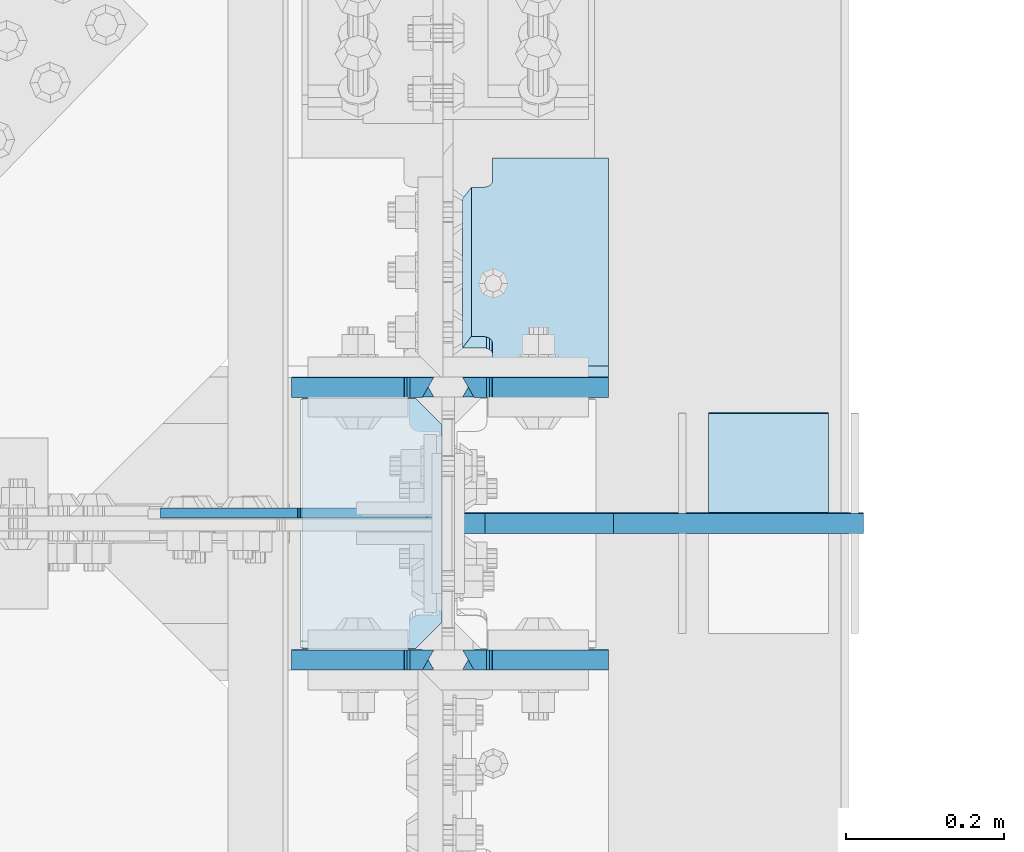
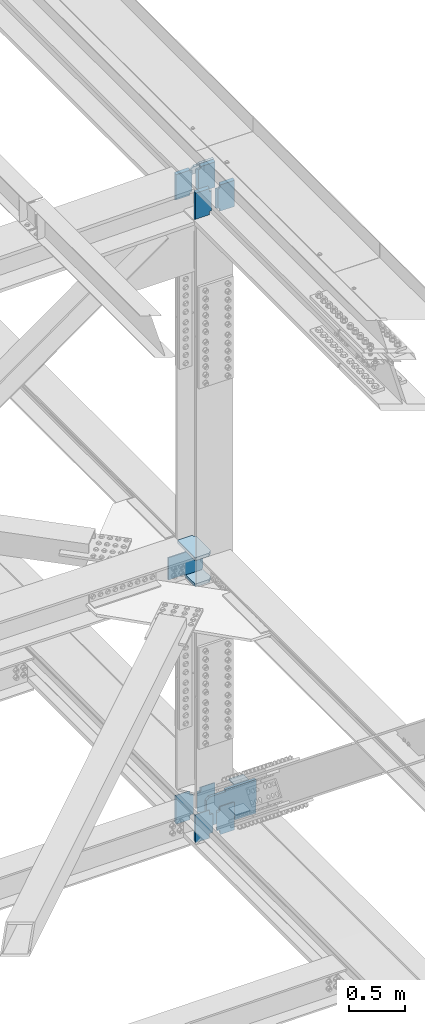
# One storey, part 3601 of 3843: 15 plates, 5 elements without a shape of their own.
"""IFC2X3 building model written with IfcOpenShell, lengths in millimetres."""

from ifc_helpers import new_model, si_unit, frame, origin_with_axes, place, context, subcontext, project, spatial, faceted_brep, material, type_object, element, aggregate, save


model = new_model("IFC2X3")

# Units and contexts
model_context = context("Model", 3, precision=1e-05, world=origin_with_axes())
body_context = subcontext(model_context, "Body", "Model", "MODEL_VIEW")
ifc_project = project(units=[si_unit("LENGTHUNIT", "METRE", prefix="MILLI"), si_unit("AREAUNIT", "SQUARE_METRE"), si_unit("VOLUMEUNIT", "CUBIC_METRE"), si_unit("MASSUNIT", "GRAM", prefix="KILO"), si_unit("TIMEUNIT", "SECOND"), si_unit("PLANEANGLEUNIT", "RADIAN"), si_unit("SOLIDANGLEUNIT", "STERADIAN"), si_unit("THERMODYNAMICTEMPERATUREUNIT", "DEGREE_CELSIUS"), si_unit("LUMINOUSINTENSITYUNIT", "LUMEN")], contexts=[model_context])

# Site, building, storey
site_placement = place(None, origin_with_axes())
site = spatial("IfcSite", under=ifc_project, at=site_placement, CompositionType="ELEMENT")
building_placement = place(site_placement, origin_with_axes())
building = spatial("IfcBuilding", under=site, at=building_placement, Name="Undefined", CompositionType="ELEMENT")
storey_placement = place(building_placement, origin_with_axes())
storey = spatial("IfcBuildingStorey", under=building, at=storey_placement, Name="Undefined", CompositionType="ELEMENT", Elevation=0.0)

# Assembly, plates
assembly_1_placement = place(storey_placement, origin_with_axes())
assembly_1 = element("IfcElementAssembly", 1, at=assembly_1_placement, inside=storey, Name="BEAM", AssemblyPlace="NOTDEFINED", PredefinedType="RIGID_FRAME")
ifc_material = material(Name="STEEL/A572-50")
plate_type_1 = type_object("IfcPlateType", PredefinedType="NOTDEFINED")
plate_1_placement = place(assembly_1_placement, frame((85852.0, 50385.630793258, 46161.5692750929), z_axis=(0.0, -0.000625967000050877, 0.999999804082638), x_axis=(-1.0, 0.0, 0.0)))
plate_1 = element("IfcPlate", 2, at=plate_1_placement, type_object=plate_type_1, material=ifc_material, Name="PLATE", context=body_context, shape_type="Brep", body=[
    faceted_brep([(146.843749999985, -12.7000000008702, 314.304894549285), (146.843749999985, 12.6999999991167, 299.813402791253), (0.0, 12.6999999991167, 299.813402791253), (0.0, -12.7000000008702, 314.304894549285), (146.843749999985, 12.7000000000553, 14.4914917584392), (146.843749999985, -12.7000000000844, 2.18278728425503e-11), (0.0, -12.6999999999971, 0.0), (0.0, 12.7000000000698, 14.4914917390415), (146.843749999985, 12.6999999999098, 38.1890602041385), (146.843749999985, -12.7000000001572, 38.1003132816259), (147.810479922569, 12.6999999998952, 43.0491693876829), (147.810479922569, -12.7000000001644, 42.9604224651703), (150.563493823051, 12.6999999998734, 47.169371005024), (150.563493823051, -12.7000000001863, 47.0806240825113), (154.683670291211, 12.6999999998734, 49.9224017096567), (154.683670291211, -12.7000000001935, 49.833654787144), (159.543749809251, 12.6999999998661, 50.8891375330786), (159.543749809251, -12.7000000001935, 50.800390610566), (170.452258242993, 12.700000000099, 50.8891375249077), (184.943749999991, -12.7000000000116, 50.8003906183731), (184.943749999991, -12.6999999997643, 263.417469235843), (170.452258242993, 12.7000000003609, 263.506216142385), (159.543749809251, 12.6999999992186, 263.506216155103), (159.543749809251, -12.7000000008484, 263.417469232591), (154.683670291211, 12.6999999992113, 264.472951978518), (154.683670291211, -12.7000000008557, 264.384205056005), (150.563493823051, 12.699999999204, 267.225982683158), (150.563493823051, -12.7000000008629, 267.137235760645), (147.810479922569, 12.6999999991895, 271.346184300499), (147.810479922569, -12.7000000008702, 271.257437377986), (146.843749999985, 12.6999999991749, 276.206293484036), (146.843749999985, -12.7000000008848, 276.117546561523)], [[[0, 1, 2, 3]], [[4, 5, 6, 7]], [[8, 9, 5, 4]], [[9, 8, 10, 11]], [[11, 10, 12, 13]], [[13, 12, 14, 15]], [[15, 14, 16, 17]], [[17, 16, 18, 19]], [[20, 19, 18, 21]], [[22, 23, 20, 21]], [[23, 22, 24, 25]], [[25, 24, 26, 27]], [[27, 26, 28, 29]], [[29, 28, 30, 31]], [[6, 5, 9, 11, 13, 15, 17, 19, 20, 23, 25, 27, 29, 31, 0, 3]], [[7, 6, 3, 2]], [[30, 28, 26, 24, 22, 21, 18, 16, 14, 12, 10, 8, 4, 7, 2, 1]], [[31, 30, 1, 0]]]),
])
plate_2_placement = place(assembly_1_placement, frame((85852.0, 50731.7055400802, 46162.082048219), z_axis=(0.0, -0.000625967000050877, 0.999999804082638), x_axis=(-1.0, 0.0, 0.0)))
plate_2 = element("IfcPlate", 3, at=plate_2_placement, type_object=plate_type_1, material=ifc_material, Name="PLATE", context=body_context, shape_type="Brep", body=[
    faceted_brep([(146.843749999985, -12.7000000001572, 38.1003132816259), (146.843749999985, 12.6999999999098, 38.1890602041385), (147.810479922569, 12.6999999998952, 43.0491693876829), (147.810479922569, -12.7000000001644, 42.9604224651703), (150.563493823051, 12.6999999998734, 47.169371005024), (150.563493823051, -12.7000000001863, 47.0806240825113), (154.683670291211, 12.6999999998734, 49.9224017096567), (154.683670291211, -12.7000000001935, 49.833654787144), (159.543749809251, 12.6999999998661, 50.8891375330786), (159.543749809251, -12.7000000001935, 50.800390610566), (170.452258242993, 12.700000000099, 50.8891375249077), (184.943749999991, -12.7000000000116, 50.8003906183731), (184.943749999991, -12.6999999997643, 263.417469235843), (170.452258242993, 12.7000000003609, 263.506216142385), (159.543749809251, 12.6999999992186, 263.506216155103), (159.543749809251, -12.7000000008484, 263.417469232591), (154.683670291211, 12.6999999992113, 264.472951978518), (154.683670291211, -12.7000000008557, 264.384205056005), (150.563493823051, 12.699999999204, 267.225982683158), (150.563493823051, -12.7000000008629, 267.137235760645), (147.810479922569, 12.6999999991895, 271.346184300499), (147.810479922569, -12.7000000008702, 271.257437377986), (146.843749999985, 12.6999999991749, 276.206293484036), (146.843749999985, -12.7000000008848, 276.117546561523), (146.843749999985, -12.7000000008484, 304.256557997855), (146.843749999985, 12.6999999991313, 289.76506625802), (0.0, 12.6999999991313, 289.76506625802), (0.0, -12.7000000008484, 304.256557997855), (0.0, -12.6999999999971, 0.0), (146.843749999985, -12.7000000000844, 2.18278728425503e-11), (146.843749999985, 12.7000000000553, 14.4914917584392), (0.0, 12.7000000000698, 14.4914917390415)], [[[0, 1, 2, 3]], [[3, 2, 4, 5]], [[5, 4, 6, 7]], [[7, 6, 8, 9]], [[9, 8, 10, 11]], [[12, 11, 10, 13]], [[14, 15, 12, 13]], [[15, 14, 16, 17]], [[17, 16, 18, 19]], [[19, 18, 20, 21]], [[21, 20, 22, 23]], [[24, 23, 22, 25]], [[26, 27, 24, 25]], [[0, 3, 5, 7, 9, 11, 12, 15, 17, 19, 21, 23, 24, 27, 28, 29]], [[1, 0, 29, 30]], [[26, 25, 22, 20, 18, 16, 14, 13, 10, 8, 6, 4, 2, 1, 30, 31]], [[27, 26, 31, 28]], [[30, 29, 28, 31]]]),
])

assembly_2_placement = place(storey_placement, origin_with_axes())
assembly_2 = element("IfcElementAssembly", 4, at=assembly_2_placement, inside=storey, Name="BEAM", AssemblyPlace="NOTDEFINED", PredefinedType="RIGID_FRAME")
plate_3_placement = place(assembly_2_placement, frame((85852.0, 50385.9360791615, 39389.280812488), z_axis=(0.0, -0.000749054000341859, 0.999999719459013), x_axis=(-1.0, 0.0, 0.0)))
plate_3 = element("IfcPlate", 5, at=plate_3_placement, type_object=plate_type_1, material=ifc_material, Name="PLATE", context=body_context, shape_type="Brep", body=[
    faceted_brep([(146.843749999985, 12.7000000002517, 314.307894929545), (0.0, 12.7000000002517, 314.307894929545), (0.0, -12.6999999998152, 299.816403173951), (146.843749999985, -12.6999999998152, 299.816403173951), (0.0, -12.7000000000044, 24.1021473603178), (0.0, 12.7000000000335, 9.46280752972962), (146.843749999985, 12.7000000000335, 9.46280752972962), (146.843749999985, -12.7000000000044, 24.1021473603178), (146.843749999985, 12.7000000000553, 47.5562269457077), (146.843749999985, -12.6999999999898, 47.4674800128851), (147.810479922569, 12.7000000000626, 52.4163361292522), (147.810479922569, -12.6999999999898, 52.3275891964222), (150.563493823051, 12.7000000000626, 56.5365377465932), (150.563493823051, -12.6999999999825, 56.4477908137706), (154.683670291211, 12.7000000000626, 59.2895684512259), (154.683670291211, -12.6999999999825, 59.200821518396), (159.543749809251, 12.7000000000626, 60.2563042746406), (159.543749809251, -12.6999999999825, 60.1675573418179), (184.943749999991, 12.7000000000626, 60.2563042746406), (170.452258243167, -12.6999999999825, 60.1675573418179), (184.943749999991, 12.7000000002081, 263.506216153903), (170.452258242891, -12.699999999837, 263.417469255888), (159.543749809251, 12.6999999992186, 263.506216155103), (159.543749809251, -12.7000000008484, 263.417469232591), (154.683670291211, 12.6999999992113, 264.472951978518), (154.683670291211, -12.7000000008557, 264.384205056005), (150.563493823051, 12.699999999204, 267.225982683158), (150.563493823051, -12.7000000008629, 267.137235760645), (147.810479922569, 12.6999999991895, 271.346184300499), (147.810479922569, -12.7000000008702, 271.257437377986), (146.843749999985, 12.6999999991749, 276.206293484036), (146.843749999985, -12.7000000008848, 276.117546561523)], [[[0, 1, 2, 3]], [[4, 5, 6, 7]], [[7, 6, 8, 9]], [[9, 8, 10, 11]], [[11, 10, 12, 13]], [[13, 12, 14, 15]], [[15, 14, 16, 17]], [[17, 16, 18, 19]], [[20, 21, 19, 18]], [[22, 23, 21, 20]], [[23, 22, 24, 25]], [[25, 24, 26, 27]], [[27, 26, 28, 29]], [[29, 28, 30, 31]], [[31, 30, 0, 3]], [[4, 7, 9, 11, 13, 15, 17, 19, 21, 23, 25, 27, 29, 31, 3, 2]], [[5, 4, 2, 1]], [[30, 28, 26, 24, 22, 20, 18, 16, 14, 12, 10, 8, 6, 5, 1, 0]]]),
])
plate_4_placement = place(assembly_2_placement, frame((85852.0, 50732.0108082423, 39389.7721094519), z_axis=(0.0, -0.000749054000341859, 0.999999719459013), x_axis=(-1.0, 0.0, 0.0)))
plate_4 = element("IfcPlate", 6, at=plate_4_placement, type_object=plate_type_1, material=ifc_material, Name="PLATE", context=body_context, shape_type="Brep", body=[
    faceted_brep([(146.843749999985, 12.7000000002372, 314.309363755092), (0.0, 12.7000000002372, 314.309363755092), (0.0, -12.6999999998152, 299.817871999512), (146.843749999985, -12.6999999998152, 299.817871999512), (146.843749999985, -12.7000000000771, 14.4914917543283), (0.0, -12.7000000000771, 14.4914917543283), (0.0, 12.6999999999971, 0.0), (146.843749999985, 12.7000000000262, 4.36557456851006e-11), (146.843749999985, 12.6999999999098, 38.1890602041385), (146.843749999985, -12.7000000001572, 38.1003132816259), (147.810479922569, 12.6999999998952, 43.0491693876829), (147.810479922569, -12.7000000001644, 42.9604224651703), (150.563493823051, 12.6999999998734, 47.169371005024), (150.563493823051, -12.7000000001863, 47.0806240825113), (154.683670291211, 12.6999999998734, 49.9224017096567), (154.683670291211, -12.7000000001935, 49.833654787144), (159.543749809251, 12.6999999998661, 50.8891375330786), (159.543749809251, -12.7000000001935, 50.800390610566), (184.943749999991, 12.7000000001572, 50.8891375333405), (170.452258242833, -12.7000000000262, 50.800390609882), (184.943749999991, 12.7000000002081, 263.506216153903), (170.452258242891, -12.699999999837, 263.417469255888), (159.543749809251, 12.6999999992186, 263.506216155103), (159.543749809251, -12.7000000008484, 263.417469232591), (154.683670291211, 12.6999999992113, 264.472951978518), (154.683670291211, -12.7000000008557, 264.384205056005), (150.563493823051, 12.699999999204, 267.225982683158), (150.563493823051, -12.7000000008629, 267.137235760645), (147.810479922569, 12.6999999991895, 271.346184300499), (147.810479922569, -12.7000000008702, 271.257437377986), (146.843749999985, 12.6999999991749, 276.206293484036), (146.843749999985, -12.7000000008848, 276.117546561523)], [[[0, 1, 2, 3]], [[4, 5, 6, 7]], [[8, 9, 4, 7]], [[9, 8, 10, 11]], [[11, 10, 12, 13]], [[13, 12, 14, 15]], [[15, 14, 16, 17]], [[17, 16, 18, 19]], [[20, 21, 19, 18]], [[22, 23, 21, 20]], [[23, 22, 24, 25]], [[25, 24, 26, 27]], [[27, 26, 28, 29]], [[29, 28, 30, 31]], [[31, 30, 0, 3]], [[5, 4, 9, 11, 13, 15, 17, 19, 21, 23, 25, 27, 29, 31, 3, 2]], [[6, 5, 2, 1]], [[30, 28, 26, 24, 22, 20, 18, 16, 14, 12, 10, 8, 7, 6, 1, 0]]]),
])

# Assembly, plate
assembly_3_placement = place(storey_placement, origin_with_axes())
assembly_3 = element("IfcElementAssembly", 7, at=assembly_3_placement, inside=storey, Name="COLUMN", AssemblyPlace="NOTDEFINED", PredefinedType="RIGID_FRAME")
plate_type_2 = type_object("IfcPlateType", PredefinedType="NOTDEFINED")
plate_5_placement = place(assembly_3_placement, frame((85640.8625, 50572.1937470839, 42209.615968616), z_axis=(-0.707106781186548, 0.0, 0.707106781186548), x_axis=(-0.707106781186548, 0.0, -0.707106781186548)))
plate_5 = element("IfcPlate", 8, at=plate_5_placement, type_object=plate_type_2, material=ifc_material, Name="PLATE", context=body_context, shape_type="Brep", body=[
    faceted_brep([(0.0, -6.3499999046162, 0.0), (-152.665721433397, -6.35000000000582, 152.665721433463), (-152.665721433397, 6.35000000000582, 152.665721433463), (7.27595761418343e-12, 6.3499999046162, 0.0), (-152.665721433092, -6.35000000000582, 179.606489796817), (-152.665721433092, 6.35000000000582, 179.606489796817), (-39.2899878478784, -6.35000000000582, 292.982223272138), (-39.2899878478784, 6.35000000000582, 292.982223272138), (-37.2516740051942, -6.35000000000582, 291.620265505095), (-37.2516740051942, 6.35000000000582, 291.620265505095), (-34.8473188920616, -6.35000000000582, 291.142009537525), (-34.8473188920616, 6.35000000000582, 291.142009537525), (-32.4429637789435, -6.35000000000582, 291.62026550512), (-32.4429637789435, 6.35000000000582, 291.62026550512), (-30.4046499362594, -6.35000000000582, 292.982223272178), (-30.4046499362594, 6.35000000000582, 292.982223272178), (90.8762668049167, -6.35000000000582, 414.263140013285), (90.8762668049167, 6.35000000000582, 414.263140013285), (261.50113310435, -6.35000000000582, 243.638273713757), (261.50113310435, 6.35000000000582, 243.638273713757), (140.316502018759, -6.35000000000582, 122.453642628203), (140.316502018759, 6.35000000000582, 122.453642628203), (138.925026635639, -6.35000000000582, 120.371152551248), (138.925026635639, 6.35000000000582, 120.371152551248), (138.43640545971, -6.35000000000582, 117.914688016841), (138.43640545971, 6.35000000000582, 117.914688016841), (138.92502663561, -6.35000000000582, 115.458223482437), (138.92502663561, 6.35000000000582, 115.458223482437), (140.316501893642, -6.34999999999854, 113.375733530571), (140.316501893642, 6.34999999999854, 113.375733530571), (26.9407683632217, -6.34999999999854, 1.30967237055302e-10), (26.9407683632217, 6.34999999999854, 1.30967237055302e-10)], [[[0, 1, 2, 3]], [[1, 4, 5, 2]], [[4, 6, 7, 5]], [[6, 8, 9, 7]], [[8, 10, 11, 9]], [[10, 12, 13, 11]], [[12, 14, 15, 13]], [[14, 16, 17, 15]], [[16, 18, 19, 17]], [[18, 20, 21, 19]], [[20, 22, 23, 21]], [[22, 24, 25, 23]], [[24, 26, 27, 25]], [[26, 28, 29, 27]], [[28, 30, 31, 29]], [[30, 0, 3, 31]], [[5, 7, 9, 11, 13, 15, 17, 19, 21, 23, 25, 27, 29, 31, 3, 2]], [[30, 28, 26, 24, 22, 20, 18, 16, 14, 12, 10, 8, 6, 4, 1, 0]]]),
])

# Plate
plate_type_3 = type_object("IfcPlateType", PredefinedType="NOTDEFINED")
plate_6_placement = place(assembly_1_placement, frame((85852.0, 51016.3130340256, 46167.7139471911), z_axis=(0.0, -0.655849171955138, 0.754891954948362), x_axis=(-1.0, 0.0, 0.0)))
plate_6 = element("IfcPlate", 9, at=plate_6_placement, type_object=plate_type_3, material=ifc_material, Name="PLATE", context=body_context, shape_type="Brep", body=[
    faceted_brep([(184.943749999991, 9.52499999934662, 346.724118745289), (173.831249999988, -9.52500000063446, 346.724118745449), (173.831249999988, -9.52500000008149, 58.1404139255465), (184.943749999991, 9.52499999988504, 58.1404139253573), (154.683670291211, -9.52500000008513, 57.1736840029625), (154.683670291211, 9.5249999998814, 57.1736840027879), (159.543749809251, 9.52499999988504, 58.1404139253573), (159.543749809251, -9.52500000008149, 58.1404139255465), (150.563493823051, -9.52500000007421, 54.4206701025396), (150.563493823051, 9.52499999989232, 54.420670102365), (147.810479922569, -9.52500000007058, 50.300493634466), (147.810479922569, 9.52499999991051, 50.3004936342913), (146.843749999985, -9.52500000005966, 45.4404141164996), (146.843749999985, 9.52499999991414, 45.440414116325), (146.843749999985, -9.52499999997599, 0.990413928826456), (146.843749999985, 9.52500000000146, 0.990413928739144), (0.0, -9.52499999997599, 0.990413928826456), (0.0, 9.52500000000146, 0.990413928739144), (0.0, -9.52500000073633, 403.87411874863), (0.0, 9.52499999923748, 403.874118748543), (146.843749999985, -9.52500000073633, 403.87411874863), (146.843749999985, 9.52499999923748, 403.874118748543), (146.843749999985, -9.52500000065993, 359.424118554482), (146.843749999985, 9.52499999932115, 359.424118554321), (147.810479922569, -9.52500000064174, 354.56403903653), (147.810479922569, 9.52499999932479, 354.564039036355), (150.563493823051, -9.5250000006381, 350.443862568442), (150.563493823051, 9.52499999934298, 350.443862568281), (154.683670291211, -9.5250000006381, 347.690848668033), (154.683670291211, 9.52499999933934, 347.690848667829), (159.543749809251, -9.52500000063446, 346.724118745449), (159.543749809251, 9.52499999934662, 346.724118745289)], [[[0, 1, 2, 3]], [[4, 5, 6, 7]], [[8, 9, 5, 4]], [[10, 11, 9, 8]], [[12, 13, 11, 10]], [[14, 15, 13, 12]], [[16, 17, 15, 14]], [[18, 19, 17, 16]], [[19, 18, 20, 21]], [[20, 22, 23, 21]], [[24, 25, 23, 22]], [[26, 27, 25, 24]], [[28, 29, 27, 26]], [[30, 31, 29, 28]], [[31, 30, 1, 0]], [[6, 5, 9, 11, 13, 15, 17, 19, 21, 23, 25, 27, 29, 31, 0, 3]], [[7, 6, 3, 2]], [[30, 28, 26, 24, 22, 20, 18, 16, 14, 12, 10, 8, 4, 7, 2, 1]]]),
])

plate_type_4 = type_object("IfcPlateType", PredefinedType="NOTDEFINED")
plate_7_placement = place(assembly_1_placement, frame((85630.54375, 50385.630793258, 46161.5692750929), z_axis=(0.0, -0.000625967000050877, 0.999999804082638), x_axis=(-1.0, 0.0, 0.0)))
plate_7 = element("IfcPlate", 10, at=plate_7_placement, type_object=plate_type_4, material=ifc_material, Name="PLATE", context=body_context, shape_type="Brep", body=[
    faceted_brep([(180.974999999991, 12.7000000000553, 14.4914917584392), (180.974999999991, -12.7000000000844, 2.18278728425503e-11), (38.1000000000058, -12.7000000000844, 2.18278728425503e-11), (38.1000000000058, 12.7000000000553, 14.4914917584392), (37.1332700774219, -12.7000000001644, 42.9604224651848), (37.1332700774219, 12.6999999998952, 43.0491693876975), (38.1000000000058, 12.6999999999098, 38.1890602041531), (38.1000000000058, -12.7000000001572, 38.1003132816404), (34.3802561769407, -12.7000000001863, 47.0806240825259), (34.3802561769407, 12.6999999998734, 47.1693710050386), (30.2600797087798, -12.7000000001935, 49.8336547871586), (30.2600797087798, 12.6999999998734, 49.9224017096712), (25.4000001907407, -12.7000000001935, 50.8003906105805), (25.4000001907407, 12.6999999998661, 50.8891375330932), (0.0, -12.7000000000262, 50.8003906045633), (14.4914917569986, 12.7000000001135, 50.8891375364256), (14.4914917569986, 12.7000000003463, 263.506216154878), (0.0, -12.6999999997643, 263.417469223023), (25.4000001907407, -12.7000000008484, 263.417469232605), (25.4000001907407, 12.6999999992186, 263.506216155118), (30.2600797087798, -12.7000000008557, 264.38420505602), (30.2600797087798, 12.6999999992113, 264.472951978532), (34.3802561769407, -12.7000000008629, 267.13723576066), (34.3802561769407, 12.699999999204, 267.225982683172), (37.1332700774219, -12.7000000008702, 271.257437378001), (37.1332700774219, 12.6999999991895, 271.346184300513), (38.1000000000058, -12.7000000008848, 276.117546561538), (38.1000000000058, 12.6999999991749, 276.206293484051), (38.1000000000058, -12.6996899253718, 314.217780397244), (38.1000000000058, 12.6999999991167, 299.813402791253), (180.974999999991, -12.7000000008702, 314.304894549285), (180.974999999991, 12.6999999991167, 299.813402791253)], [[[0, 1, 2, 3]], [[4, 5, 6, 7]], [[8, 9, 5, 4]], [[10, 11, 9, 8]], [[12, 13, 11, 10]], [[13, 12, 14, 15]], [[16, 15, 14, 17]], [[18, 19, 16, 17]], [[20, 21, 19, 18]], [[22, 23, 21, 20]], [[24, 25, 23, 22]], [[26, 27, 25, 24]], [[27, 26, 28, 29]], [[30, 31, 29, 28]], [[6, 5, 9, 11, 13, 15, 16, 19, 21, 23, 25, 27, 29, 31, 0, 3]], [[7, 6, 3, 2]], [[30, 28, 26, 24, 22, 20, 18, 17, 14, 12, 10, 8, 4, 7, 2, 1]], [[31, 30, 1, 0]]]),
])

plate_8_placement = place(assembly_1_placement, frame((85630.54375, 50731.7055400801, 46162.082048219), z_axis=(0.0, -0.000625967000050877, 0.999999804082638), x_axis=(-1.0, 0.0, 0.0)))
plate_8 = element("IfcPlate", 11, at=plate_8_placement, type_object=plate_type_4, material=ifc_material, Name="PLATE", context=body_context, shape_type="Brep", body=[
    faceted_brep([(180.974999999991, 12.7000000000553, 14.4914917584392), (180.974999999991, -12.7000000000844, 2.18278728425503e-11), (38.1000000000058, -12.7000000000844, 2.18278728425503e-11), (38.1000000000058, 12.7000000000553, 14.4914917584392), (37.1332700774219, -12.7000000001644, 42.9604224651848), (37.1332700774219, 12.6999999998952, 43.0491693876975), (38.1000000000058, 12.6999999999098, 38.1890602041531), (38.1000000000058, -12.7000000001572, 38.1003132816404), (34.3802561769407, -12.7000000001863, 47.0806240825259), (34.3802561769407, 12.6999999998734, 47.1693710050386), (30.2600797087798, -12.7000000001935, 49.8336547871586), (30.2600797087798, 12.6999999998734, 49.9224017096712), (25.4000001907407, -12.7000000001935, 50.8003906105805), (25.4000001907407, 12.6999999998661, 50.8891375330932), (0.0, -12.7000000000262, 50.8003906045633), (14.4914917569986, 12.7000000001135, 50.8891375364256), (14.4914917569986, 12.7000000003463, 263.506216154878), (0.0, -12.6999999997643, 263.417469223023), (25.4000001907407, -12.7000000008484, 263.417469232605), (25.4000001907407, 12.6999999992186, 263.506216155118), (30.2600797087798, -12.7000000008557, 264.38420505602), (30.2600797087798, 12.6999999992113, 264.472951978532), (34.3802561769407, -12.7000000008629, 267.13723576066), (34.3802561769407, 12.699999999204, 267.225982683172), (37.1332700774219, -12.7000000008702, 271.257437378001), (37.1332700774219, 12.6999999991895, 271.346184300513), (38.1000000000058, -12.7000000008848, 276.117546561538), (38.1000000000058, 12.6999999991749, 276.206293484051), (38.1000000000058, -12.7000000008484, 304.256557997833), (38.1000000000058, 12.6999999991313, 289.765066257998), (180.974999999991, -12.7000000008484, 304.256557997833), (180.974999999991, 12.6999999991313, 289.765066257998)], [[[0, 1, 2, 3]], [[4, 5, 6, 7]], [[8, 9, 5, 4]], [[10, 11, 9, 8]], [[12, 13, 11, 10]], [[13, 12, 14, 15]], [[16, 15, 14, 17]], [[18, 19, 16, 17]], [[20, 21, 19, 18]], [[22, 23, 21, 20]], [[24, 25, 23, 22]], [[26, 27, 25, 24]], [[28, 29, 27, 26]], [[30, 31, 29, 28]], [[6, 5, 9, 11, 13, 15, 16, 19, 21, 23, 25, 27, 29, 31, 0, 3]], [[7, 6, 3, 2]], [[30, 28, 26, 24, 22, 20, 18, 17, 14, 12, 10, 8, 4, 7, 2, 1]], [[31, 30, 1, 0]]]),
])

aggregate(assembly_1, [plate_6, plate_1, plate_7, plate_2, plate_8])

plate_9_placement = place(assembly_2_placement, frame((85630.54375, 50385.9360791615, 39389.280812488), z_axis=(0.0, -0.000749054000341859, 0.999999719459013), x_axis=(-1.0, 0.0, 0.0)))
plate_9 = element("IfcPlate", 12, at=plate_9_placement, type_object=plate_type_4, material=ifc_material, Name="PLATE", context=body_context, shape_type="Brep", body=[
    faceted_brep([(180.974999999991, 12.7000000000335, 9.46280752972234), (180.974999999991, -12.7000000000044, 24.1021473603105), (38.1000000000058, -12.7000000000044, 24.1021473603105), (38.1000000000058, 12.7000000000335, 9.46280752972234), (38.1000000000058, -12.6999999999898, 47.4674800128923), (38.1000000000058, 12.7000000000553, 47.556226945715), (37.1332700774219, -12.6999999999898, 52.3275891964295), (37.1332700774219, 12.7000000000626, 52.4163361292594), (34.3802561769407, -12.6999999999825, 56.4477908137778), (34.3802561769407, 12.7000000000626, 56.5365377466005), (30.2600797087798, -12.6999999999825, 59.2008215184032), (30.2600797087798, 12.7000000000626, 59.2895684512332), (25.4000001907407, -12.6999999999825, 60.1675573418252), (25.4000001907407, 12.7000000000626, 60.2563042746478), (14.491491756824, -12.6999999999825, 60.1675573418252), (0.0, 12.7000000000626, 60.2563042746478), (14.4914917568531, -12.7000000008484, 263.417469232605), (0.0, 12.6999999992186, 263.506216155118), (25.4000001907407, -12.7000000008484, 263.417469232605), (25.4000001907407, 12.6999999992186, 263.506216155118), (30.2600797087798, -12.7000000008557, 264.38420505602), (30.2600797087798, 12.6999999992113, 264.472951978532), (34.3802561769407, -12.7000000008629, 267.13723576066), (34.3802561769407, 12.699999999204, 267.225982683172), (37.1332700774219, -12.7000000008702, 271.257437378001), (37.1332700774219, 12.6999999991895, 271.346184300513), (38.1000000000058, -12.7000000008848, 276.117546561538), (38.1000000000058, 12.6999999991749, 276.206293484051), (38.1000000000058, -12.6998041531115, 299.816516246101), (38.1000000000058, 12.7000000002517, 314.307894929545), (180.974999999991, 12.7000000002517, 314.307894929545), (180.974999999991, -12.6999999998152, 299.816403173951)], [[[0, 1, 2, 3]], [[4, 5, 3, 2]], [[6, 7, 5, 4]], [[8, 9, 7, 6]], [[10, 11, 9, 8]], [[12, 13, 11, 10]], [[13, 12, 14, 15]], [[16, 17, 15, 14]], [[18, 19, 17, 16]], [[20, 21, 19, 18]], [[22, 23, 21, 20]], [[24, 25, 23, 22]], [[26, 27, 25, 24]], [[27, 26, 28, 29]], [[0, 3, 5, 7, 9, 11, 13, 15, 17, 19, 21, 23, 25, 27, 29, 30]], [[1, 0, 30, 31]], [[26, 24, 22, 20, 18, 16, 14, 12, 10, 8, 6, 4, 2, 1, 31, 28]], [[30, 29, 28, 31]]]),
])

plate_10_placement = place(assembly_2_placement, frame((85630.54375, 50732.0108082423, 39389.7721094519), z_axis=(0.0, -0.000749054000341859, 0.999999719459013), x_axis=(-1.0, 0.0, 0.0)))
plate_10 = element("IfcPlate", 13, at=plate_10_placement, type_object=plate_type_4, material=ifc_material, Name="PLATE", context=body_context, shape_type="Brep", body=[
    faceted_brep([(180.974999999991, -12.7000000000844, 14.4914917571878), (38.1000000000058, -12.7000000000771, 14.4914917543283), (38.1000000000058, 12.7000000000262, 4.36557456851006e-11), (180.974999999991, 12.7000000000844, -7.27595761418343e-12), (37.1332700774219, -12.7000000001644, 42.9604224651848), (37.1332700774219, 12.6999999998952, 43.0491693876975), (38.1000000000058, 12.6999999999098, 38.1890602041531), (38.1000000000058, -12.7000000001572, 38.1003132816404), (34.3802561769407, -12.7000000001863, 47.0806240825259), (34.3802561769407, 12.6999999998734, 47.1693710050386), (30.2600797087798, -12.7000000001935, 49.8336547871586), (30.2600797087798, 12.6999999998734, 49.9224017096712), (25.4000001907407, -12.7000000001935, 50.8003906105805), (25.4000001907407, 12.6999999998661, 50.8891375330932), (14.4914917568531, -12.7000000001935, 50.8003906105805), (0.0, 12.6999999998661, 50.8891375330932), (14.4914917568531, -12.7000000008484, 263.417469232605), (0.0, 12.6999999992186, 263.506216155118), (25.4000001907407, -12.7000000008484, 263.417469232605), (25.4000001907407, 12.6999999992186, 263.506216155118), (30.2600797087798, -12.7000000008557, 264.38420505602), (30.2600797087798, 12.6999999992113, 264.472951978532), (34.3802561769407, -12.7000000008629, 267.13723576066), (34.3802561769407, 12.699999999204, 267.225982683172), (37.1332700774219, -12.7000000008702, 271.257437378001), (37.1332700774219, 12.6999999991895, 271.346184300513), (38.1000000000058, -12.7000000008848, 276.117546561538), (38.1000000000058, 12.6999999991749, 276.206293484051), (38.1000000000058, -12.6998009485396, 299.817986921815), (38.1000000000058, 12.7000000002372, 314.309363755092), (180.974999999991, 12.7000000002372, 314.309363755092), (180.974999999991, -12.6999999998152, 299.817871999512)], [[[0, 1, 2, 3]], [[4, 5, 6, 7]], [[8, 9, 5, 4]], [[10, 11, 9, 8]], [[12, 13, 11, 10]], [[13, 12, 14, 15]], [[16, 17, 15, 14]], [[18, 19, 17, 16]], [[20, 21, 19, 18]], [[22, 23, 21, 20]], [[24, 25, 23, 22]], [[26, 27, 25, 24]], [[27, 26, 28, 29]], [[30, 29, 28, 31]], [[30, 31, 0, 3]], [[6, 5, 9, 11, 13, 15, 17, 19, 21, 23, 25, 27, 29, 30, 3, 2]], [[7, 6, 2, 1]], [[31, 28, 26, 24, 22, 20, 18, 16, 14, 12, 10, 8, 4, 7, 1, 0]]]),
])

plate_type_5 = type_object("IfcPlateType", PredefinedType="NOTDEFINED")
plate_11_placement = place(assembly_3_placement, frame((85463.0624999931, 50717.449957981, 42174.3501993517), z_axis=(0.0, -1.0, 0.0), x_axis=(1.0, 0.0, 0.0)))
plate_11 = element("IfcPlate", 14, at=plate_11_placement, type_object=plate_type_5, material=ifc_material, Name="PLATE", context=body_context, shape_type="Brep", body=[
    faceted_brep([(0.0, -15.875, 0.0), (0.0, -15.875, 317.5), (0.0, 15.875, 317.5), (0.0, 15.875, 0.0), (144.462498511086, -15.874999999156, 317.499999999665), (144.462498511086, 15.875000000844, 317.499999999578), (177.800000033079, -15.8749999992506, 284.162498473786), (177.800000033079, 15.8750000007494, 284.162498473699), (177.800000003888, -15.8749999999054, 33.3375015259226), (177.800000003888, 15.8750000000946, 33.3375015258353), (144.462498474124, -15.875, 0.0), (144.462498474124, 15.875, 0.0)], [[[0, 1, 2, 3]], [[1, 4, 5, 2]], [[4, 6, 7, 5]], [[6, 8, 9, 7]], [[8, 10, 11, 9]], [[10, 0, 3, 11]], [[5, 7, 9, 11, 3, 2]], [[10, 8, 6, 4, 1, 0]]]),
])

plate_12_placement = place(assembly_3_placement, frame((85463.0624999931, 50717.4499479805, 42460.1006307201), z_axis=(0.0, -1.0, 0.0), x_axis=(1.0, 0.0, 0.0)))
plate_12 = element("IfcPlate", 15, at=plate_12_placement, type_object=plate_type_5, material=ifc_material, Name="PLATE", context=body_context, shape_type="Brep", body=[
    faceted_brep([(0.0, -15.875, 0.0), (0.0, -15.875, 317.5), (0.0, 15.875, 317.5), (0.0, 15.875, 0.0), (144.462498511086, -15.874999999156, 317.499999999665), (144.462498511086, 15.875000000844, 317.499999999578), (177.800000033079, -15.8749999992506, 284.162498473786), (177.800000033079, 15.8750000007494, 284.162498473699), (177.800000003888, -15.8749999999054, 33.3375015259226), (177.800000003888, 15.8750000000946, 33.3375015258353), (144.462498474124, -15.875, 0.0), (144.462498474124, 15.875, 0.0)], [[[0, 1, 2, 3]], [[1, 4, 5, 2]], [[4, 6, 7, 5]], [[6, 8, 9, 7]], [[8, 10, 11, 9]], [[10, 0, 3, 11]], [[5, 7, 9, 11, 3, 2]], [[10, 8, 6, 4, 1, 0]]]),
])

aggregate(assembly_3, [plate_11, plate_12, plate_5])

plate_type_6 = type_object("IfcPlateType", PredefinedType="NOTDEFINED")
plate_13_placement = place(assembly_2_placement, frame((86175.8500000026, 50559.8815932075, 39362.4764603309), z_axis=(0.0, -0.00349395200045545, 0.999993896131081), x_axis=(-1.0, 0.0, 0.0)))
plate_13 = element("IfcPlate", 16, at=plate_13_placement, type_object=plate_type_6, material=ifc_material, Name="STIFFENER", context=body_context, shape_type="Brep", body=[
    faceted_brep([(0.0, -12.6999999999971, 0.0), (1.43627403303981e-08, -12.7000000003172, 368.282421855467), (1.43627403303981e-08, 12.6999999996769, 368.282421855489), (0.0, 12.6999999999971, 0.0), (317.500000026223, -12.7000000003172, 368.282421839234), (317.500000026223, 12.6999999996769, 368.282421839256), (317.500000024767, -12.7000000002881, 342.88242181766), (317.500000024767, 12.6999999996915, 342.882421817681), (480.218749970372, -12.7000000002881, 342.882421787188), (480.218749970372, 12.6999999996915, 342.88242178721), (511.968749969019, -12.700000000259, 311.132421781258), (511.968749969019, 12.6999999997206, 311.132421781287), (511.968749958221, -12.7000000000553, 57.1500000187953), (511.968749958221, 12.6999999999389, 57.1500000188171), (480.218749956868, -12.7000000000116, 25.4000000166852), (480.218749956868, 12.6999999999825, 25.4000000167216), (317.500000000146, -12.7000000000116, 25.4000000058295), (317.500000000146, 12.699999999968, 25.4000000058659), (317.50000000211, -12.6999999999971, -8.14907252788544e-10), (317.50000000211, 12.6999999999971, -7.93079379945993e-10)], [[[0, 1, 2, 3]], [[1, 4, 5, 2]], [[4, 6, 7, 5]], [[6, 8, 9, 7]], [[8, 10, 11, 9]], [[10, 12, 13, 11]], [[12, 14, 15, 13]], [[14, 16, 17, 15]], [[16, 18, 19, 17]], [[18, 0, 3, 19]], [[5, 7, 9, 11, 13, 15, 17, 19, 3, 2]], [[18, 16, 14, 12, 10, 8, 6, 4, 1, 0]]]),
])

aggregate(assembly_2, [plate_13, plate_3, plate_9, plate_4, plate_10])

# Assembly, plate
assembly_4_placement = place(storey_placement, origin_with_axes())
assembly_4 = element("IfcElementAssembly", 17, at=assembly_4_placement, inside=storey, Name="PLATE", AssemblyPlace="NOTDEFINED", PredefinedType="RIGID_FRAME")
plate_type_7 = type_object("IfcPlateType", PredefinedType="NOTDEFINED")
plate_14_placement = place(assembly_4_placement, frame((86131.4000000045, 50572.4870874804, 39389.5541377016), z_axis=(0.0, 0.999993896131081, 0.00349395200045545), x_axis=(-1.0, 0.0, 0.0)))
plate_14 = element("IfcPlate", 18, at=plate_14_placement, type_object=plate_type_7, material=ifc_material, Name="PLATE", context=body_context, shape_type="Brep", body=[
    faceted_brep([(0.0, -4.76249999999709, 0.0), (-5.82076609134674e-11, -4.76249999972788, 126.999999995154), (-5.82076609134674e-11, 4.76250000024447, 126.999999995183), (0.0, 4.76249999999709, 0.0), (152.399999999951, -4.76249999972788, 126.999999995154), (152.399999999951, 4.76250000024447, 126.999999995183), (152.399993896484, -4.76249999999709, 0.0), (152.399993896484, 4.76249999999709, 0.0)], [[[0, 1, 2, 3]], [[1, 4, 5, 2]], [[4, 6, 7, 5]], [[6, 0, 3, 7]], [[5, 7, 3, 2]], [[6, 4, 1, 0]]]),
])
aggregate(assembly_4, [plate_14])

assembly_5_placement = place(storey_placement, origin_with_axes())
assembly_5 = element("IfcElementAssembly", 19, at=assembly_5_placement, inside=storey, Name="PLATE", AssemblyPlace="NOTDEFINED", PredefinedType="RIGID_FRAME")
plate_15_placement = place(assembly_5_placement, frame((86131.3999975899, 50571.3777525507, 39707.0525234094), z_axis=(0.0, 0.999993896131081, 0.00349395200045545), x_axis=(-1.0, 0.0, 0.0)))
plate_15 = element("IfcPlate", 20, at=plate_15_placement, type_object=plate_type_7, material=ifc_material, Name="PLATE", context=body_context, shape_type="Brep", body=[
    faceted_brep([(0.0, -4.76249999999709, 0.0), (-5.82076609134674e-11, -4.76249999972788, 126.999999995154), (-5.82076609134674e-11, 4.76250000024447, 126.999999995183), (0.0, 4.76249999999709, 0.0), (152.399999999951, -4.76249999972788, 126.999999995154), (152.399999999951, 4.76250000024447, 126.999999995183), (152.399993896484, -4.76249999999709, 0.0), (152.399993896484, 4.76249999999709, 0.0)], [[[0, 1, 2, 3]], [[1, 4, 5, 2]], [[4, 6, 7, 5]], [[6, 0, 3, 7]], [[5, 7, 3, 2]], [[6, 4, 1, 0]]]),
])
aggregate(assembly_5, [plate_15])

save(model, "model.ifc")
